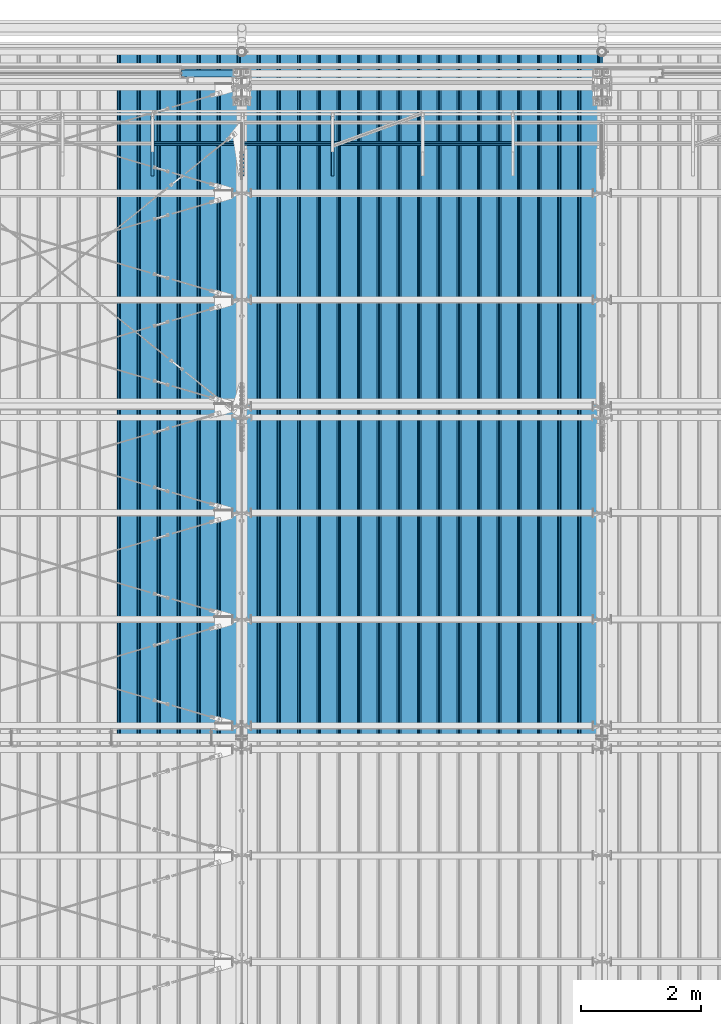
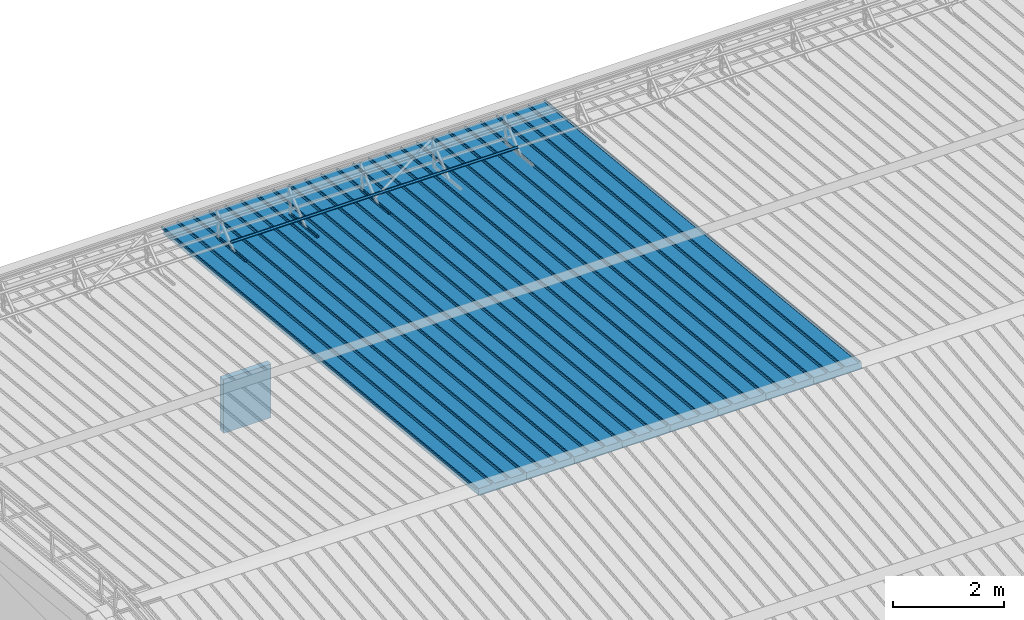
# One storey, part 54 of 709: 13 beams, 13 elements without a shape of their own.
"""IFC4 building model written with IfcOpenShell, lengths in millimetres."""

from ifc_helpers import new_model, si_unit, direction, frame, origin_with_axes, place, context, subcontext, project, spatial, line, indexed_curve, outline, extrude, material, element, aggregate, save


model = new_model("IFC4")

# Units and contexts
model_context = context("Model", 3, precision=0.2, world=origin_with_axes(), true_north=direction((0.0, 1.0)))
body_context = subcontext(model_context, "Body", "Model", "MODEL_VIEW")
ifc_project = project(units=[si_unit("LENGTHUNIT", "METRE", prefix="MILLI"), si_unit("AREAUNIT", "SQUARE_METRE"), si_unit("VOLUMEUNIT", "CUBIC_METRE"), si_unit("MASSUNIT", "GRAM", prefix="KILO"), si_unit("TIMEUNIT", "SECOND"), si_unit("PLANEANGLEUNIT", "RADIAN"), si_unit("SOLIDANGLEUNIT", "STERADIAN"), si_unit("THERMODYNAMICTEMPERATUREUNIT", "DEGREE_CELSIUS"), si_unit("LUMINOUSINTENSITYUNIT", "LUMEN")], contexts=[model_context])

# Site, building, storey
site_placement = place(None, origin_with_axes())
site = spatial("IfcSite", under=ifc_project, at=site_placement, CompositionType="ELEMENT")
building_placement = place(site_placement, origin_with_axes())
building = spatial("IfcBuilding", under=site, at=building_placement, Name="Undefined", CompositionType="ELEMENT")
storey_placement = place(building_placement, origin_with_axes())
storey = spatial("IfcBuildingStorey", under=building, at=storey_placement, Name="Undefined", CompositionType="ELEMENT", Elevation=0.0)

# Assembly, beam
assembly_1_placement = place(storey_placement, frame((15452.44, 11009.10459, 8419.96887), z_axis=(1.0, 0.0, 0.0), x_axis=(0.0, 0.9950371902, -0.099503719)))
assembly_1 = element("IfcElementAssembly", 1, at=assembly_1_placement, inside=storey)
ifc_material_1 = material(Name="Insulation", Category="Insulation")
beam_1_placement = place(assembly_1_placement, origin_with_axes())
beam_1 = element("IfcBeam", 2, at=beam_1_placement, material=ifc_material_1, ObjectType="P-99", context=body_context, shape_type="SolidModel", body=[
    extrude(outline(indexed_curve([(-509.8453, 89.5), (-490.1547, 89.5), (-471.67949, 57.5), (-471.67949, -88.5), (-436.67949, -88.5), (-436.67949, -91.5), (562.55841, -91.5), (562.55841, -89.5), (527.55841, -89.5), (527.55841, 57.5), (510.2379, 88.5), (489.7621, 88.5), (472.44159, 58.5), (196.71923, 58.5), (177.66667, 91.5), (155.66667, 91.5), (136.61411, 58.5), (-136.61411, 58.5), (-155.66667, 91.5), (-177.66667, 91.5), (-196.71923, 58.5), (-469.94744, 58.5), (-489.0, 91.5), (-511.0, 91.5), (-527.16581, 63.5), (-525.43376, 62.5)], segments=[line(1, 2, 3, 4, 5, 6, 7, 8, 9, 10, 11, 12, 13, 14, 15, 16, 17, 18, 19, 20, 21, 22, 23, 24, 25, 26, 1)])), frame((0.0, 0.0, 0.0), z_axis=(-1.0, 0.0, 0.0), x_axis=(0.0, 0.0, 1.0)), (0.0, 0.0, -1.0), 11459.0),
])
aggregate(assembly_1, [beam_1])

assembly_2_placement = place(storey_placement, frame((14452.44, 11009.10459, 8419.96887), z_axis=(1.0, 0.0, 0.0), x_axis=(0.0, 0.9950371902, -0.099503719)))
assembly_2 = element("IfcElementAssembly", 3, at=assembly_2_placement, inside=storey)
beam_2_placement = place(assembly_2_placement, origin_with_axes())
beam_2 = element("IfcBeam", 4, at=beam_2_placement, material=ifc_material_1, ObjectType="P-99", context=body_context, shape_type="SolidModel", body=[
    extrude(outline(indexed_curve([(-509.8453, 89.5), (-490.1547, 89.5), (-471.67949, 57.5), (-471.67949, -88.5), (-436.67949, -88.5), (-436.67949, -91.5), (562.55841, -91.5), (562.55841, -89.5), (527.55841, -89.5), (527.55841, 57.5), (510.2379, 88.5), (489.7621, 88.5), (472.44159, 58.5), (196.71923, 58.5), (177.66667, 91.5), (155.66667, 91.5), (136.61411, 58.5), (-136.61411, 58.5), (-155.66667, 91.5), (-177.66667, 91.5), (-196.71923, 58.5), (-469.94744, 58.5), (-489.0, 91.5), (-511.0, 91.5), (-527.16581, 63.5), (-525.43376, 62.5)], segments=[line(1, 2, 3, 4, 5, 6, 7, 8, 9, 10, 11, 12, 13, 14, 15, 16, 17, 18, 19, 20, 21, 22, 23, 24, 25, 26, 1)])), frame((0.0, 0.0, 0.0), z_axis=(-1.0, 0.0, 0.0), x_axis=(0.0, 0.0, 1.0)), (0.0, 0.0, -1.0), 11459.0),
])
aggregate(assembly_2, [beam_2])

assembly_3_placement = place(storey_placement, frame((13452.44, 11009.10459, 8419.96887), z_axis=(1.0, 0.0, 0.0), x_axis=(0.0, 0.9950371902, -0.099503719)))
assembly_3 = element("IfcElementAssembly", 5, at=assembly_3_placement, inside=storey)
beam_3_placement = place(assembly_3_placement, origin_with_axes())
beam_3 = element("IfcBeam", 6, at=beam_3_placement, material=ifc_material_1, ObjectType="P-99", context=body_context, shape_type="SolidModel", body=[
    extrude(outline(indexed_curve([(-509.8453, 89.5), (-490.1547, 89.5), (-471.67949, 57.5), (-471.67949, -88.5), (-436.67949, -88.5), (-436.67949, -91.5), (562.55841, -91.5), (562.55841, -89.5), (527.55841, -89.5), (527.55841, 57.5), (510.2379, 88.5), (489.7621, 88.5), (472.44159, 58.5), (196.71923, 58.5), (177.66667, 91.5), (155.66667, 91.5), (136.61411, 58.5), (-136.61411, 58.5), (-155.66667, 91.5), (-177.66667, 91.5), (-196.71923, 58.5), (-469.94744, 58.5), (-489.0, 91.5), (-511.0, 91.5), (-527.16581, 63.5), (-525.43376, 62.5)], segments=[line(1, 2, 3, 4, 5, 6, 7, 8, 9, 10, 11, 12, 13, 14, 15, 16, 17, 18, 19, 20, 21, 22, 23, 24, 25, 26, 1)])), frame((0.0, 0.0, 0.0), z_axis=(-1.0, 0.0, 0.0), x_axis=(0.0, 0.0, 1.0)), (0.0, 0.0, -1.0), 11459.0),
])
aggregate(assembly_3, [beam_3])

assembly_4_placement = place(storey_placement, frame((12452.44, 11009.10459, 8419.96887), z_axis=(1.0, 0.0, 0.0), x_axis=(0.0, 0.9950371902, -0.099503719)))
assembly_4 = element("IfcElementAssembly", 7, at=assembly_4_placement, inside=storey)
beam_4_placement = place(assembly_4_placement, origin_with_axes())
beam_4 = element("IfcBeam", 8, at=beam_4_placement, material=ifc_material_1, ObjectType="P-99", context=body_context, shape_type="SolidModel", body=[
    extrude(outline(indexed_curve([(-509.8453, 89.5), (-490.1547, 89.5), (-471.67949, 57.5), (-471.67949, -88.5), (-436.67949, -88.5), (-436.67949, -91.5), (562.55841, -91.5), (562.55841, -89.5), (527.55841, -89.5), (527.55841, 57.5), (510.2379, 88.5), (489.7621, 88.5), (472.44159, 58.5), (196.71923, 58.5), (177.66667, 91.5), (155.66667, 91.5), (136.61411, 58.5), (-136.61411, 58.5), (-155.66667, 91.5), (-177.66667, 91.5), (-196.71923, 58.5), (-469.94744, 58.5), (-489.0, 91.5), (-511.0, 91.5), (-527.16581, 63.5), (-525.43376, 62.5)], segments=[line(1, 2, 3, 4, 5, 6, 7, 8, 9, 10, 11, 12, 13, 14, 15, 16, 17, 18, 19, 20, 21, 22, 23, 24, 25, 26, 1)])), frame((0.0, 0.0, 0.0), z_axis=(-1.0, 0.0, 0.0), x_axis=(0.0, 0.0, 1.0)), (0.0, 0.0, -1.0), 11459.0),
])
aggregate(assembly_4, [beam_4])

assembly_5_placement = place(storey_placement, frame((11452.44, 11009.10459, 8419.96887), z_axis=(1.0, 0.0, 0.0), x_axis=(0.0, 0.9950371902, -0.099503719)))
assembly_5 = element("IfcElementAssembly", 9, at=assembly_5_placement, inside=storey)
beam_5_placement = place(assembly_5_placement, origin_with_axes())
beam_5 = element("IfcBeam", 10, at=beam_5_placement, material=ifc_material_1, ObjectType="P-99", context=body_context, shape_type="SolidModel", body=[
    extrude(outline(indexed_curve([(-509.8453, 89.5), (-490.1547, 89.5), (-471.67949, 57.5), (-471.67949, -88.5), (-436.67949, -88.5), (-436.67949, -91.5), (562.55841, -91.5), (562.55841, -89.5), (527.55841, -89.5), (527.55841, 57.5), (510.2379, 88.5), (489.7621, 88.5), (472.44159, 58.5), (196.71923, 58.5), (177.66667, 91.5), (155.66667, 91.5), (136.61411, 58.5), (-136.61411, 58.5), (-155.66667, 91.5), (-177.66667, 91.5), (-196.71923, 58.5), (-469.94744, 58.5), (-489.0, 91.5), (-511.0, 91.5), (-527.16581, 63.5), (-525.43376, 62.5)], segments=[line(1, 2, 3, 4, 5, 6, 7, 8, 9, 10, 11, 12, 13, 14, 15, 16, 17, 18, 19, 20, 21, 22, 23, 24, 25, 26, 1)])), frame((0.0, 0.0, 0.0), z_axis=(-1.0, 0.0, 0.0), x_axis=(0.0, 0.0, 1.0)), (0.0, 0.0, -1.0), 11459.0),
])
aggregate(assembly_5, [beam_5])

assembly_6_placement = place(storey_placement, frame((10452.44, 11009.10459, 8419.96887), z_axis=(1.0, 0.0, 0.0), x_axis=(0.0, 0.9950371902, -0.099503719)))
assembly_6 = element("IfcElementAssembly", 11, at=assembly_6_placement, inside=storey)
beam_6_placement = place(assembly_6_placement, origin_with_axes())
beam_6 = element("IfcBeam", 12, at=beam_6_placement, material=ifc_material_1, ObjectType="P-99", context=body_context, shape_type="SolidModel", body=[
    extrude(outline(indexed_curve([(-509.8453, 89.5), (-490.1547, 89.5), (-471.67949, 57.5), (-471.67949, -88.5), (-436.67949, -88.5), (-436.67949, -91.5), (562.55841, -91.5), (562.55841, -89.5), (527.55841, -89.5), (527.55841, 57.5), (510.2379, 88.5), (489.7621, 88.5), (472.44159, 58.5), (196.71923, 58.5), (177.66667, 91.5), (155.66667, 91.5), (136.61411, 58.5), (-136.61411, 58.5), (-155.66667, 91.5), (-177.66667, 91.5), (-196.71923, 58.5), (-469.94744, 58.5), (-489.0, 91.5), (-511.0, 91.5), (-527.16581, 63.5), (-525.43376, 62.5)], segments=[line(1, 2, 3, 4, 5, 6, 7, 8, 9, 10, 11, 12, 13, 14, 15, 16, 17, 18, 19, 20, 21, 22, 23, 24, 25, 26, 1)])), frame((0.0, 0.0, 0.0), z_axis=(-1.0, 0.0, 0.0), x_axis=(0.0, 0.0, 1.0)), (0.0, 0.0, -1.0), 11459.0),
])
aggregate(assembly_6, [beam_6])

assembly_7_placement = place(storey_placement, frame((9452.44, 11009.10459, 8419.96887), z_axis=(1.0, 0.0, 0.0), x_axis=(0.0, 0.9950371902, -0.099503719)))
assembly_7 = element("IfcElementAssembly", 13, at=assembly_7_placement, inside=storey)
beam_7_placement = place(assembly_7_placement, origin_with_axes())
beam_7 = element("IfcBeam", 14, at=beam_7_placement, material=ifc_material_1, ObjectType="P-99", context=body_context, shape_type="SolidModel", body=[
    extrude(outline(indexed_curve([(-509.8453, 89.5), (-490.1547, 89.5), (-471.67949, 57.5), (-471.67949, -88.5), (-436.67949, -88.5), (-436.67949, -91.5), (562.55841, -91.5), (562.55841, -89.5), (527.55841, -89.5), (527.55841, 57.5), (510.2379, 88.5), (489.7621, 88.5), (472.44159, 58.5), (196.71923, 58.5), (177.66667, 91.5), (155.66667, 91.5), (136.61411, 58.5), (-136.61411, 58.5), (-155.66667, 91.5), (-177.66667, 91.5), (-196.71923, 58.5), (-469.94744, 58.5), (-489.0, 91.5), (-511.0, 91.5), (-527.16581, 63.5), (-525.43376, 62.5)], segments=[line(1, 2, 3, 4, 5, 6, 7, 8, 9, 10, 11, 12, 13, 14, 15, 16, 17, 18, 19, 20, 21, 22, 23, 24, 25, 26, 1)])), frame((0.0, 0.0, 0.0), z_axis=(-1.0, 0.0, 0.0), x_axis=(0.0, 0.0, 1.0)), (0.0, 0.0, -1.0), 11459.0),
])
aggregate(assembly_7, [beam_7])

assembly_8_placement = place(storey_placement, frame((8452.44, 11009.10459, 8419.96887), z_axis=(1.0, 0.0, 0.0), x_axis=(0.0, 0.9950371902, -0.099503719)))
assembly_8 = element("IfcElementAssembly", 15, at=assembly_8_placement, inside=storey)
beam_8_placement = place(assembly_8_placement, origin_with_axes())
beam_8 = element("IfcBeam", 16, at=beam_8_placement, material=ifc_material_1, ObjectType="P-99", context=body_context, shape_type="SolidModel", body=[
    extrude(outline(indexed_curve([(-509.8453, 89.5), (-490.1547, 89.5), (-471.67949, 57.5), (-471.67949, -88.5), (-436.67949, -88.5), (-436.67949, -91.5), (562.55841, -91.5), (562.55841, -89.5), (527.55841, -89.5), (527.55841, 57.5), (510.2379, 88.5), (489.7621, 88.5), (472.44159, 58.5), (196.71923, 58.5), (177.66667, 91.5), (155.66667, 91.5), (136.61411, 58.5), (-136.61411, 58.5), (-155.66667, 91.5), (-177.66667, 91.5), (-196.71923, 58.5), (-469.94744, 58.5), (-489.0, 91.5), (-511.0, 91.5), (-527.16581, 63.5), (-525.43376, 62.5)], segments=[line(1, 2, 3, 4, 5, 6, 7, 8, 9, 10, 11, 12, 13, 14, 15, 16, 17, 18, 19, 20, 21, 22, 23, 24, 25, 26, 1)])), frame((0.0, 0.0, 0.0), z_axis=(-1.0, 0.0, 0.0), x_axis=(0.0, 0.0, 1.0)), (0.0, 0.0, -1.0), 11459.0),
])
aggregate(assembly_8, [beam_8])

assembly_9_placement = place(storey_placement, frame((11515.0, 21349.29926, 7565.33969), z_axis=(0.0, 0.099503719, 0.9950371902), x_axis=(0.0, -0.9950371902, 0.099503719)))
assembly_9 = element("IfcElementAssembly", 17, at=assembly_9_placement, inside=storey)
ifc_material_2 = material(Name="Steel_Undefined", Category="STEEL")
beam_9_placement = place(assembly_9_placement, origin_with_axes())
beam_9 = element("IfcBeam", 18, at=beam_9_placement, material=ifc_material_2, ObjectType="601", context=body_context, shape_type="SolidModel", body=[
    extrude(outline(indexed_curve([(-20.0, -25.0), (20.0, -25.0), (20.0, -22.5), (-17.5, -22.5), (-17.5, 22.5), (20.0, 22.5), (20.0, 25.0), (-20.0, 25.0)], segments=[line(1, 2, 3, 4, 5, 6, 7, 8, 1)])), frame((0.0, 0.0, 0.0), z_axis=(-1.0, 0.0, 0.0), x_axis=(0.0, 0.0, 1.0)), (0.0, 0.0, -1.0), 1000.0),
])
aggregate(assembly_9, [beam_9])

assembly_10_placement = place(storey_placement, frame((10015.0, 21349.29926, 7565.33969), z_axis=(0.0, 0.099503719, 0.9950371902), x_axis=(0.0, -0.9950371902, 0.099503719)))
assembly_10 = element("IfcElementAssembly", 19, at=assembly_10_placement, inside=storey)
beam_10_placement = place(assembly_10_placement, origin_with_axes())
beam_10 = element("IfcBeam", 20, at=beam_10_placement, material=ifc_material_2, ObjectType="601", context=body_context, shape_type="SolidModel", body=[
    extrude(outline(indexed_curve([(-20.0, -25.0), (20.0, -25.0), (20.0, -22.5), (-17.5, -22.5), (-17.5, 22.5), (20.0, 22.5), (20.0, 25.0), (-20.0, 25.0)], segments=[line(1, 2, 3, 4, 5, 6, 7, 8, 1)])), frame((0.0, 0.0, 0.0), z_axis=(-1.0, 0.0, 0.0), x_axis=(0.0, 0.0, 1.0)), (0.0, 0.0, -1.0), 1000.0),
])
aggregate(assembly_10, [beam_10])

assembly_11_placement = place(storey_placement, frame((14515.0, 20892.41357, 7747.26788), z_axis=(0.0, -0.6332377902, 0.7739572992), x_axis=(-1.0, 0.0, 0.0)))
assembly_11 = element("IfcElementAssembly", 21, at=assembly_11_placement, inside=storey)
beam_11_placement = place(assembly_11_placement, origin_with_axes())
beam_11 = element("IfcBeam", 22, at=beam_11_placement, material=ifc_material_2, ObjectType="606", context=body_context, shape_type="SolidModel", body=[
    extrude(outline(indexed_curve([(-20.0, -25.0), (20.0, -25.0), (20.0, -22.5), (-17.5, -22.5), (-17.5, 22.5), (20.0, 22.5), (20.0, 25.0), (-20.0, 25.0)], segments=[line(1, 2, 3, 4, 5, 6, 7, 8, 1)])), frame((0.0, 0.0, 0.0), z_axis=(-1.0, 0.0, 0.0), x_axis=(0.0, 0.0, 1.0)), (0.0, 0.0, -1.0), 6000.0),
])
aggregate(assembly_11, [beam_11])

assembly_12_placement = place(storey_placement, frame((8515.0, 21349.29926, 7565.33969), z_axis=(0.0, 0.099503719, 0.9950371902), x_axis=(0.0, -0.9950371902, 0.099503719)))
assembly_12 = element("IfcElementAssembly", 23, at=assembly_12_placement, inside=storey)
beam_12_placement = place(assembly_12_placement, origin_with_axes())
beam_12 = element("IfcBeam", 24, at=beam_12_placement, material=ifc_material_2, ObjectType="601", context=body_context, shape_type="SolidModel", body=[
    extrude(outline(indexed_curve([(-20.0, -25.0), (20.0, -25.0), (20.0, -22.5), (-17.5, -22.5), (-17.5, 22.5), (20.0, 22.5), (20.0, 25.0), (-20.0, 25.0)], segments=[line(1, 2, 3, 4, 5, 6, 7, 8, 1)])), frame((0.0, 0.0, 0.0), z_axis=(-1.0, 0.0, 0.0), x_axis=(0.0, 0.0, 1.0)), (0.0, 0.0, -1.0), 1000.0),
])
aggregate(assembly_12, [beam_12])

assembly_13_placement = place(storey_placement, frame((9000.0, 22060.0, 3275.0), z_axis=(0.0, 0.0, -1.0), x_axis=(1.0, 0.0, 0.0)))
assembly_13 = element("IfcElementAssembly", 25, at=assembly_13_placement, inside=storey)
beam_13_placement = place(assembly_13_placement, origin_with_axes())
beam_13 = element("IfcBeam", 26, at=beam_13_placement, material=ifc_material_1, ObjectType="P-110", context=body_context, shape_type="SolidModel", body=[
    extrude(outline(indexed_curve([(-595.0, -60.0), (595.0, -60.0), (595.0, 60.0), (-595.0, 60.0)], segments=[line(1, 2, 3, 4, 1)])), frame((0.0, 0.0, 0.0), z_axis=(-1.0, 0.0, 0.0), x_axis=(0.0, 0.0, 1.0)), (0.0, 0.0, -1.0), 990.0),
])
aggregate(assembly_13, [beam_13])

save(model, "model.ifc")
